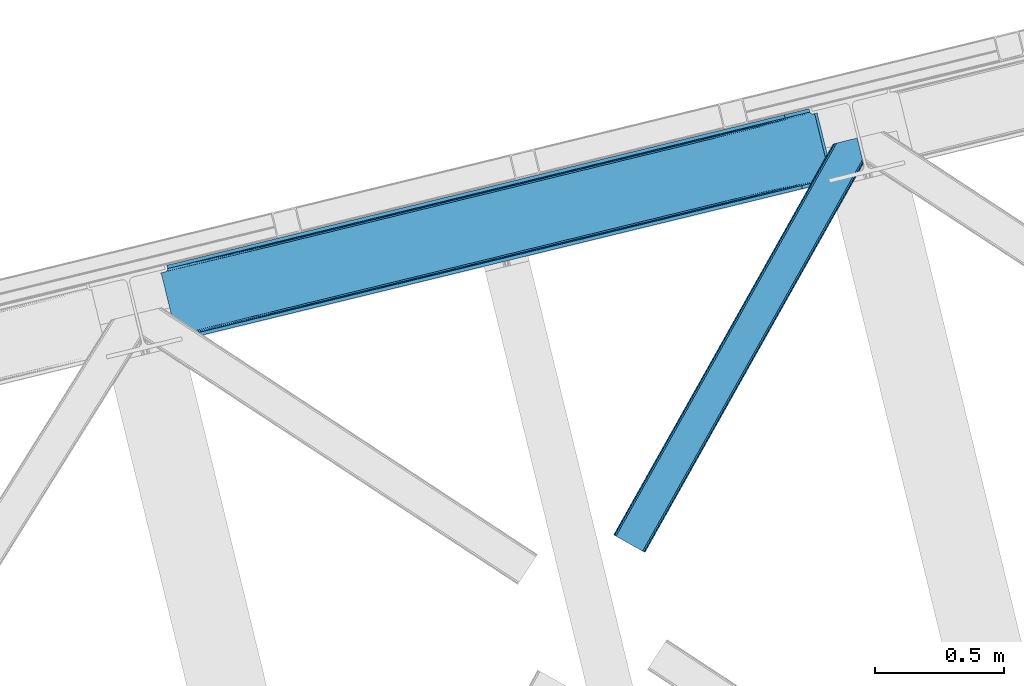
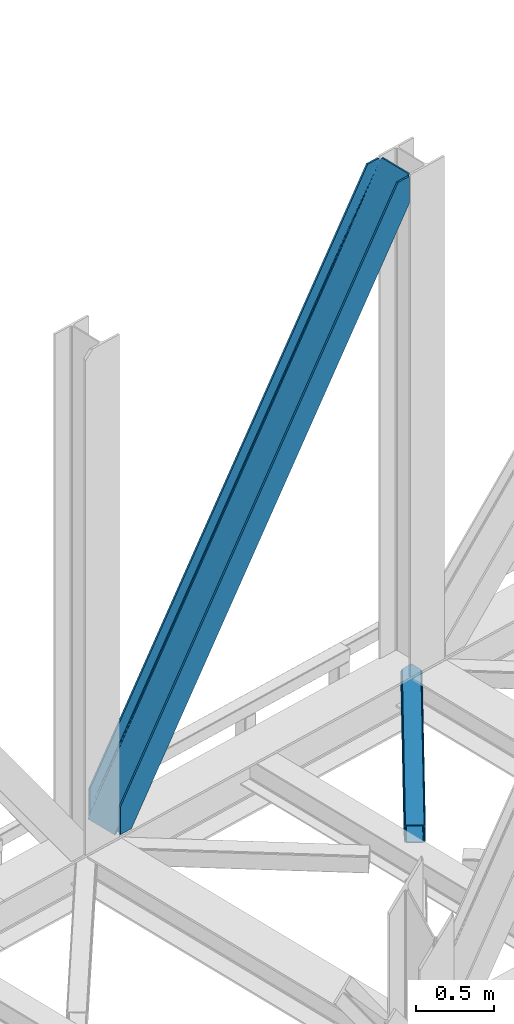
# One storey, part 78 of 92: 2 members.
"""IFC4 building model written with IfcOpenShell, lengths in millimetres."""

from ifc_helpers import new_model, entity, si_unit, converted_unit, derived_unit, direction, frame, origin, place, context, subcontext, project, spatial, triangles, type_object, element, save


model = new_model("IFC4")

# Units and contexts
model_context = context("Model", 3, precision=0.01, world=origin(), true_north=direction((6.12303176911189e-17, 1.0)))
plan_context = context("Plan", 3, precision=0.01, world=origin(), true_north=direction((6.12303176911189e-17, 1.0)))
body_context = subcontext(model_context, "Body", "Model", "MODEL_VIEW")
ifc_project = project(units=[si_unit("LENGTHUNIT", "METRE", prefix="MILLI"), si_unit("AREAUNIT", "SQUARE_METRE"), si_unit("VOLUMEUNIT", "CUBIC_METRE"), converted_unit("PLANEANGLEUNIT", "DEGREE", entity("IfcRatioMeasure", 0.0174532925199433), si_unit("PLANEANGLEUNIT", "RADIAN"), dimensions=[0, 0, 0, 0, 0, 0, 0]), si_unit("MASSUNIT", "GRAM", prefix="KILO"), derived_unit("MASSDENSITYUNIT", [(si_unit("MASSUNIT", "GRAM", prefix="KILO"), 1), (si_unit("LENGTHUNIT", "METRE"), -3)]), derived_unit("MOMENTOFINERTIAUNIT", [(si_unit("LENGTHUNIT", "METRE"), 4)]), si_unit("TIMEUNIT", "SECOND"), si_unit("FREQUENCYUNIT", "HERTZ"), si_unit("THERMODYNAMICTEMPERATUREUNIT", "DEGREE_CELSIUS"), derived_unit("THERMALTRANSMITTANCEUNIT", [(si_unit("MASSUNIT", "GRAM", prefix="KILO"), 1), (si_unit("THERMODYNAMICTEMPERATUREUNIT", "KELVIN"), -1), (si_unit("TIMEUNIT", "SECOND"), -3)]), derived_unit("VOLUMETRICFLOWRATEUNIT", [(si_unit("LENGTHUNIT", "METRE"), 3), (si_unit("TIMEUNIT", "SECOND"), -1)]), derived_unit("MASSFLOWRATEUNIT", [(si_unit("MASSUNIT", "GRAM", prefix="KILO"), 1), (si_unit("TIMEUNIT", "SECOND"), -1)]), derived_unit("ROTATIONALFREQUENCYUNIT", [(si_unit("TIMEUNIT", "SECOND"), -1)]), si_unit("ELECTRICCURRENTUNIT", "AMPERE"), si_unit("ELECTRICVOLTAGEUNIT", "VOLT"), si_unit("POWERUNIT", "WATT"), si_unit("FORCEUNIT", "NEWTON", prefix="KILO"), si_unit("ILLUMINANCEUNIT", "LUX"), si_unit("LUMINOUSFLUXUNIT", "LUMEN"), si_unit("LUMINOUSINTENSITYUNIT", "CANDELA"), derived_unit("USERDEFINED", [(si_unit("MASSUNIT", "GRAM", prefix="KILO"), -1), (si_unit("LENGTHUNIT", "METRE"), -2), (si_unit("TIMEUNIT", "SECOND"), 3), (si_unit("LUMINOUSFLUXUNIT", "LUMEN"), 1)]), derived_unit("LINEARVELOCITYUNIT", [(si_unit("LENGTHUNIT", "METRE"), 1), (si_unit("TIMEUNIT", "SECOND"), -1)]), si_unit("PRESSUREUNIT", "PASCAL"), derived_unit("USERDEFINED", [(si_unit("LENGTHUNIT", "METRE"), -2), (si_unit("MASSUNIT", "GRAM", prefix="KILO"), 1), (si_unit("TIMEUNIT", "SECOND"), -2)]), derived_unit("LINEARFORCEUNIT", [(si_unit("MASSUNIT", "GRAM", prefix="KILO"), 1), (si_unit("LENGTHUNIT", "METRE"), 1), (si_unit("TIMEUNIT", "SECOND"), -2), (si_unit("LENGTHUNIT", "METRE"), -1)]), derived_unit("PLANARFORCEUNIT", [(si_unit("MASSUNIT", "GRAM", prefix="KILO"), 1), (si_unit("LENGTHUNIT", "METRE"), 1), (si_unit("TIMEUNIT", "SECOND"), -2), (si_unit("LENGTHUNIT", "METRE"), -2)])], contexts=[model_context, plan_context])

# Site, building, storey
site_placement = place(None, origin())
site = spatial("IfcSite", under=ifc_project, at=site_placement, CompositionType="ELEMENT")
building_placement = place(site_placement, origin())
building = spatial("IfcBuilding", under=site, at=building_placement, CompositionType="ELEMENT")
storey_placement = place(building_placement, frame((0.0, 0.0, 15900.0)))
storey = spatial("IfcBuildingStorey", under=building, at=storey_placement, Name="05", CompositionType="ELEMENT", Elevation=15900.0)

# Members
member_type_1 = type_object("IfcMemberType", PredefinedType="BRACE")
member_1_placement = place(storey_placement, frame((-11645.76, 17824.6, 3695.0)))
element("IfcMember", 1, at=member_1_placement, inside=storey, type_object=member_type_1, ObjectType="Steel Vertical Brace", PredefinedType="BRACE", context=body_context, shape_type="Tessellation", body=[
    triangles([(2543.71740875244, 876.026760864261, 3910.2403930664), (2543.86100463867, 877.205758666994, 3909.96134033203), (2542.34249267578, 876.834851074222, 3911.00081176758), (2544.23714447021, 869.063232421875, 3911.00081176758), (2527.1870223999, 873.140890502931, 3906.29412231445), (2530.23276672363, 873.882705688477, 3911.00081176758), (2527.1870223999, 873.140890502931, 3884.1908203125), (2518.86892547608, 874.429183959961, 3898.31321411133), (2521.01472473145, 873.423431396484, 3899.16199951172), (2522.8994934082, 872.957180786136, 3877.06799926758), (2518.86892547608, 874.429183959961, 3868.81036376953), (2517.28820800781, 875.594229125978, 3898.850390625), (2517.28820800781, 875.594229125978, 3864.49202270508), (2515.87201538086, 877.455743408205, 3857.29478759765), (2515.70574645996, 877.331332397462, 3901.61533813476), (2513.89597320557, 881.222955322268, 3911.00081176758), (2514.70987701416, 878.98239440918, 3851.39514770508), (2514.17793273926, 880.262548828126, 3838.64708862305), (2514.70987701416, 878.98239440918, 3906.82664794922), (2514.37326965332, 879.734674072268, 3911.00081176758), (2514.17793273926, 880.262548828126, 3698.36960449219), (2513.89597320557, 881.222955322268, 3698.30216674805), (2522.8994934082, 872.957180786136, 3900.77120361328), (1281.82757263184, 579.864605712894, 1933.79126586914), (121.508862304689, 297.023730468751, 0.0), (1706.06330566406, 683.275735473635, 2589.5349609375), (2130.29787597656, 786.688027954104, 3245.28098144531), (857.58835144043, 476.451150512698, 1278.04757080078), (30.7527740478527, 274.901824951172, 0.0), (433.353781127931, 373.040020751956, 622.301550292967), (2511.05370483398, 892.881546020508, 3698.30216674805), (118.429980468751, 309.654354858401, 0.0), (2511.05370483398, 892.881546020508, 3911.00081176758), (2415.21013641357, 869.519018554689, 3911.00081176758), (23.883425903321, 286.608087158205, 214.700848388671), (23.883425903321, 286.608087158205, 0.0), (26.9576568603516, 273.658877563477, 0.0), (26.7251129150391, 274.948333740234, 0.0), (26.7251129150391, 274.948333740234, 214.700848388671), (2509.04452514648, 879.011462402344, 3911.00081176758), (2418.28901824951, 856.888394165042, 3911.00081176758), (26.9169616699219, 273.965835571289, 214.633410644528), (1250.04927978516, 572.117404174805, 1964.95680541992), (1676.92671203613, 676.173843383789, 2624.78862304687), (2103.8058883667, 780.230282592776, 3284.61811523437), (823.166033935548, 468.060964965822, 1305.12731323242), (26.9169616699219, 273.965835571289, 74.3536010742173), (396.287438964844, 364.004525756838, 645.295495605467), (25.435656738282, 266.62907409668, 14.6874755859353), (23.9973724365245, 264.751281738281, 13.8410156249993), (22.5346710205085, 263.467639160157, 35.9326904296868), (25.435656738282, 266.62907409668, 44.192651367186), (26.2995574951183, 268.389431762698, 14.1502990722656), (26.0007385253921, 268.181304931641, 48.2249633789033), (26.9088226318363, 270.661386108401, 54.6571289062485), (26.9088226318363, 270.661386108401, 11.3853515624978), (27.0332336425781, 272.584524536134, 61.6055419921868), (27.0332336425781, 272.584524536134, 6.17404174804688), (22.5346710205085, 263.467639160157, 12.2294860839829), (18.6395599365242, 261.656121826174, 28.8121948242188), (18.6395599365242, 261.656121826174, 6.70889282226563), (0.0, 257.112213134766, 0.0), (14.3014526367188, 260.598046875002, 0.0), (412.366690063478, 356.486380004884, 636.079779052732), (0.597637939454216, 256.057626342776, 0.0), (4.08579711914172, 249.874282836914, 0.0), (2122.62276306152, 766.289273071292, 3274.64197998047), (2534.31914520264, 866.644775390625, 3911.00081176758), (2530.82982330322, 872.828118896487, 3911.00081176758), (2119.88455810547, 772.712136840823, 3275.40239868164), (2109.70145874024, 780.257025146486, 3280.80206909179), (2115.34762573242, 777.616488647462, 3277.56505737305), (407.82975769043, 361.391894531251, 638.242437744138), (402.183590698243, 364.031268310548, 641.479449462888), (415.109545898438, 350.064678955081, 635.319360351561), (829.062185668947, 468.087707519531, 1301.30894165039), (1255.93961791992, 572.142984008791, 1961.14075927734), (1682.81821289063, 676.199423217775, 2620.97025146484), (834.707189941408, 465.447171020511, 1298.07192993164), (1261.58578491211, 569.503610229494, 1957.90374755859), (1688.46903076172, 673.561212158205, 2617.73323974609), (839.24877319336, 460.543981933595, 1295.90927124023), (1266.12736816406, 564.600421142579, 1955.74108886719), (1693.00596313477, 668.656860351563, 2615.57058105469), (841.988140869142, 454.121118164065, 1295.15117797851), (1268.86557312012, 558.177557373048, 1954.98067016601), (1695.74416809082, 662.233996582032, 2614.81248779297), (428.11107788086, 370.350650024415, 626.119921874997), (424.31247253418, 365.409091186524, 629.35693359375), (2119.48225708008, 772.614468383792, 3254.49669799805), (2121.25307922363, 779.057098388672, 3252.33403930664), (423.061386108398, 352.004095458986, 632.280010986327), (14.0096099853527, 252.292739868164, 0.0), (14.2619201660164, 259.388818359377, 0.0), (422.53699951172, 358.966461181641, 631.519592285156), (2125.05110321045, 783.998657226563, 3249.09702758789), (846.772732543946, 462.377590942386, 1287.26328735351), (847.297119140625, 455.415225219727, 1288.02370605469), (1271.00730285645, 565.789883422854, 1943.00930786133), (1271.53168945313, 558.827517700196, 1943.76740112304), (1695.24303588867, 669.201013183596, 2598.75300292969), (1695.76742248535, 662.238647460938, 2599.5110961914), (2120.00199279785, 765.650939941406, 3255.25711669922), (848.548205566407, 468.821383666993, 1285.10062866211), (1272.78277587891, 572.232513427734, 1940.84664916992), (1697.01850891113, 675.644805908203, 2596.59034423828), (852.345648193361, 473.762942504884, 1281.86361694336), (1276.58138122559, 577.175234985352, 1937.60963745117), (1700.81595153809, 680.586364746094, 2593.35333251953), (2589.49949798584, 640.273709106448, 3911.00081176758), (2177.80311584473, 539.918206787112, 3274.64197998047), (1324.04592590332, 331.805328369141, 1954.98067016601), (1750.92452087402, 435.861767578128, 2614.81248779297), (897.168493652345, 227.750051879884, 1295.15117797851), (470.289898681642, 123.693612670901, 635.319360351561), (59.2673126220707, 23.50205383301, 0.0), (2599.41749725342, 642.691003417971, 3911.00081176758), (2175.18234558106, 539.278710937502, 3255.25711669922), (1750.94777526856, 435.867581176761, 2599.5110961914), (1326.71204223633, 332.455288696292, 1943.76740112304), (902.477471923828, 229.044158935547, 1288.02370605469), (478.241738891602, 125.631866455078, 632.280010986327), (69.1899627685561, 25.9216735839873, 0.0), (59.015002441407, 16.4071380615242, 0.0), (72.6781219482436, 19.7383300781257, 0.0), (58.9696563720718, 15.1955841064482, 0.0), (73.2711090087905, 18.6825805664084, 0.0), (77.6092163085941, 19.739492797853, 6.70889282226563), (77.6092163085941, 19.739492797853, 28.8121948242188), (2589.24718780518, 633.177630615235, 3911.00081176758), (2601.31214904785, 634.918222045901, 3911.00081176758), (2589.2024230957, 631.967239379883, 3911.00081176758), (2602.83066101074, 635.289129638673, 3909.96134033203), (2602.16035308838, 636.269302368164, 3910.2403930664), (2586.15667877197, 631.22426147461, 3906.29412231445), (2586.15667877197, 631.22426147461, 3884.1908203125), (2572.75110168457, 617.663461303713, 3911.00081176758), (2577.81474609375, 619.473815917969, 3911.00081176758), (2577.76765594482, 620.297021484377, 3906.82664794922), (2172.75865631104, 521.571652221683, 3280.80206909179), (2577.89206695557, 622.220159912111, 3901.61533813476), (2578.49726257324, 624.490951538086, 3898.850390625), (2582.2662185669, 629.413906860354, 3900.77120361328), (2178.32750244141, 532.955841064453, 3275.40239868164), (2580.80293579102, 628.130264282227, 3899.15967407226), (2579.36465148926, 626.252471923828, 3898.31321411133), (2176.55668029785, 526.513211059573, 3277.56505737305), (470.809634399415, 116.730084228519, 636.079779052732), (469.03881225586, 110.288616943362, 638.242437744138), (81.900814819337, 19.9232025146484, 35.9326904296868), (85.9319641113289, 18.4523620605469, 44.192651367186), (87.5086120605483, 17.2861541748061, 48.5109924316384), (2167.51188354492, 518.882281494141, 3284.61811523437), (459.994015502931, 102.656524658203, 645.295495605467), (465.24020690918, 105.345895385744, 641.479449462888), (90.6235382080085, 12.618997192385, 74.3536010742173), (90.0910125732426, 13.899151611331, 61.6055419921868), (88.9282928466801, 15.4258026123061, 55.7059020996094), (897.692880249024, 220.787686157229, 1295.90927124023), (1324.5703125, 324.844125366213, 1955.74108886719), (1751.4489074707, 428.899401855469, 2615.57058105469), (895.916244506836, 214.343893432619, 1298.07192993164), (1322.79483947754, 318.400332641602, 1957.90374755859), (1749.67808532715, 422.457934570313, 2617.73323974609), (892.118801879884, 209.402334594728, 1301.30894165039), (1318.99739685059, 313.458773803712, 1961.14075927734), (1745.87599182129, 417.514050292972, 2620.97025146484), (886.872610473634, 206.71296386719, 1305.12731323242), (1313.75469360352, 310.770565795901, 1964.95680541992), (1740.63328857422, 414.827005004885, 2624.78862304687), (90.6235382080085, 12.618997192385, 214.633410644528), (2481.9955947876, 595.541555786134, 3911.00081176758), (491.167694091797, 111.666439819339, 626.119921874997), (89.0945617675789, 15.5502136230498, 11.3853515624978), (87.5086120605483, 17.2861541748061, 14.1502990722656), (90.0910125732426, 13.899151611331, 6.17404174804688), (480.981106567384, 119.210165405275, 631.519592285156), (83.7855834960938, 19.4581146240234, 13.8386901855447), (81.900814819337, 19.9232025146484, 12.2294860839829), (85.9319641113289, 18.4523620605469, 14.6874755859353), (485.52152709961, 114.305813598636, 629.35693359375), (2182.46213378906, 527.953820800783, 3252.33403930664), (2582.2662185669, 629.413906860354, 3877.06799926758), (2579.36465148926, 626.252471923828, 3868.81036376953), (2177.92520141602, 532.858172607423, 3254.49669799805), (2578.79608154297, 624.697915649416, 3864.77572631836), (2577.89206695557, 622.220159912111, 3858.34588623047), (2188.10830078125, 525.313284301759, 3249.09702758789), (2577.76765594482, 620.297021484377, 3851.39514770508), (94.4593505859375, 13.5538238525405, 0.0), (90.5188934326179, 12.9108398437529, 0.0), (497.059194946291, 111.692019653321, 622.301550292967), (2577.88392791748, 618.914547729495, 3838.64708862305), (2194.00445251465, 525.340026855469, 3245.28098144531), (915.403427124023, 215.07756958008, 1281.86361694336), (921.294927978517, 215.10431213379, 1278.04757080078), (1339.63799743652, 318.489862060549, 1937.60963745117), (1345.53414916992, 318.516604614259, 1933.79126586914), (1763.87373046875, 421.900991821291, 2593.35333251953), (1769.76871948242, 421.928897094727, 2589.5349609375), (909.757260131837, 217.718106079104, 1285.10062866211), (1333.99183044434, 321.129235839846, 1940.84664916992), (1758.22756347656, 424.541528320315, 2596.59034423828), (905.215676879883, 222.621295166016, 1287.26328735351), (1329.45024719238, 326.033587646485, 1943.00930786133), (1753.68598022461, 429.444717407227, 2598.75300292969), (90.9049163818363, 11.6585906982436, 0.0), (90.9049163818363, 11.6585906982436, 214.700848388671), (2485.07389526367, 582.910931396487, 3911.00081176758), (93.7466033935561, 0.0, 214.700848388671), (93.7466033935561, 0.0, 0.0), (188.293157958986, 23.046267700196, 0.0), (185.214276123048, 35.6768920898467, 0.0), (2577.88392791748, 618.914547729495, 3698.36960449219), (2578.07577667236, 617.93204956055, 3911.00081176758), (2578.07577667236, 617.93204956055, 3698.30216674805), (2580.91746368408, 606.273458862306, 3698.30216674805), (2580.91746368408, 606.273458862306, 3911.00081176758)], [[1, 2, 3], [3, 4, 1], [3, 5, 6], [5, 3, 2], [7, 5, 2], [8, 9, 10], [10, 11, 8], [8, 11, 12], [13, 12, 11], [14, 15, 12], [16, 17, 18], [19, 15, 14], [16, 20, 19], [19, 17, 16], [14, 17, 19], [18, 21, 22], [22, 16, 18], [13, 14, 12], [9, 23, 10], [5, 7, 23], [10, 23, 7], [21, 24, 25], [26, 21, 27], [21, 26, 24], [21, 18, 27], [28, 25, 24], [29, 25, 30], [28, 30, 25], [31, 22, 32], [22, 21, 25], [25, 32, 22], [16, 22, 33], [31, 33, 22], [34, 31, 35], [31, 34, 33], [32, 35, 31], [36, 35, 32], [32, 29, 36], [29, 32, 25], [37, 38, 29], [38, 36, 29], [38, 39, 35], [35, 36, 38], [16, 33, 40], [20, 16, 40], [34, 40, 33], [34, 41, 40], [39, 34, 35], [41, 39, 42], [39, 41, 34], [41, 42, 43], [43, 44, 41], [44, 45, 41], [40, 41, 45], [46, 43, 42], [42, 47, 48], [48, 46, 42], [49, 50, 51], [51, 52, 49], [53, 49, 52], [52, 54, 53], [55, 56, 53], [57, 58, 55], [56, 55, 58], [38, 37, 58], [58, 47, 38], [39, 38, 47], [47, 42, 39], [57, 47, 58], [54, 55, 53], [50, 59, 51], [51, 59, 60], [61, 60, 59], [60, 61, 62], [63, 62, 61], [64, 65, 66], [67, 68, 69], [70, 8, 12], [70, 69, 23], [23, 9, 70], [9, 8, 70], [69, 5, 23], [69, 6, 5], [71, 72, 12], [12, 15, 71], [19, 40, 45], [45, 71, 19], [73, 74, 57], [57, 55, 73], [64, 51, 60], [60, 65, 64], [60, 62, 65], [64, 73, 54], [54, 52, 64], [52, 51, 64], [55, 54, 73], [74, 48, 47], [47, 57, 74], [19, 20, 40], [15, 19, 71], [12, 72, 70], [69, 70, 67], [66, 75, 64], [76, 46, 48], [48, 74, 76], [77, 43, 46], [46, 76, 77], [78, 44, 43], [43, 77, 78], [71, 45, 78], [44, 78, 45], [79, 76, 73], [74, 73, 76], [80, 77, 79], [76, 79, 77], [81, 78, 80], [77, 80, 78], [72, 71, 78], [78, 81, 72], [82, 79, 64], [73, 64, 79], [83, 80, 79], [79, 82, 83], [84, 81, 80], [80, 83, 84], [70, 72, 81], [81, 84, 70], [85, 82, 64], [64, 75, 85], [86, 83, 82], [82, 85, 86], [87, 84, 86], [83, 86, 84], [67, 70, 87], [84, 87, 70], [88, 89, 53], [53, 56, 88], [30, 88, 58], [58, 29, 30], [90, 10, 7], [7, 1, 90], [7, 2, 1], [90, 91, 13], [13, 11, 90], [11, 10, 90], [92, 93, 94], [95, 49, 53], [95, 94, 61], [61, 59, 95], [59, 50, 95], [50, 49, 95], [94, 63, 61], [53, 89, 95], [94, 95, 92], [14, 91, 17], [14, 13, 91], [91, 96, 17], [18, 17, 96], [96, 27, 18], [58, 37, 29], [56, 58, 88], [97, 98, 92], [92, 95, 97], [99, 100, 98], [98, 97, 99], [101, 102, 100], [100, 99, 101], [90, 103, 102], [102, 101, 90], [1, 4, 90], [103, 90, 4], [104, 97, 95], [95, 89, 104], [105, 99, 104], [97, 104, 99], [106, 101, 105], [99, 105, 101], [91, 90, 101], [101, 106, 91], [107, 104, 88], [89, 88, 104], [108, 105, 107], [104, 107, 105], [109, 106, 105], [105, 108, 109], [96, 91, 106], [106, 109, 96], [28, 107, 88], [88, 30, 28], [24, 108, 107], [107, 28, 24], [26, 109, 24], [108, 24, 109], [27, 96, 26], [109, 26, 96], [110, 68, 67], [87, 111, 67], [112, 113, 87], [112, 87, 86], [67, 111, 110], [87, 113, 111], [85, 114, 112], [112, 86, 85], [85, 75, 115], [66, 116, 75], [85, 115, 114], [75, 116, 115], [4, 117, 118], [119, 103, 118], [100, 102, 119], [100, 119, 120], [118, 103, 4], [119, 102, 103], [98, 100, 120], [120, 121, 98], [121, 122, 92], [123, 93, 122], [121, 92, 98], [122, 93, 92], [66, 116, 93], [116, 124, 125], [124, 126, 125], [62, 65, 63], [65, 66, 94], [93, 116, 123], [127, 125, 126], [125, 123, 116], [93, 94, 66], [94, 63, 65], [128, 129, 126], [126, 127, 128], [110, 130, 131], [130, 132, 131], [6, 69, 3], [3, 69, 68], [110, 117, 68], [68, 117, 4], [110, 131, 117], [4, 3, 68], [133, 134, 131], [117, 131, 134], [131, 135, 133], [131, 132, 135], [135, 136, 133], [137, 138, 139], [140, 141, 142], [140, 139, 141], [130, 143, 135], [144, 145, 143], [144, 146, 145], [143, 130, 144], [135, 132, 130], [144, 147, 142], [142, 146, 144], [111, 144, 130], [148, 115, 116], [149, 150, 151], [148, 124, 129], [129, 149, 148], [129, 150, 149], [124, 126, 129], [151, 152, 149], [116, 124, 148], [130, 110, 111], [142, 147, 140], [137, 139, 153], [140, 153, 139], [154, 155, 156], [157, 156, 155], [157, 149, 158], [157, 155, 149], [152, 158, 149], [159, 114, 148], [115, 148, 114], [160, 112, 159], [114, 159, 112], [161, 113, 112], [112, 160, 161], [144, 111, 113], [113, 161, 144], [162, 159, 148], [148, 149, 162], [163, 160, 162], [159, 162, 160], [164, 161, 163], [160, 163, 161], [147, 144, 164], [161, 164, 144], [165, 162, 149], [149, 155, 165], [166, 163, 162], [162, 165, 166], [167, 164, 163], [163, 166, 167], [140, 147, 167], [164, 167, 147], [168, 165, 154], [155, 154, 165], [169, 166, 168], [165, 168, 166], [170, 167, 169], [166, 169, 167], [153, 140, 167], [167, 170, 153], [169, 171, 172], [172, 153, 170], [153, 172, 137], [170, 169, 172], [171, 169, 168], [168, 154, 171], [156, 171, 154], [173, 174, 175], [173, 176, 174], [177, 178, 179], [177, 180, 178], [179, 128, 177], [128, 125, 177], [128, 127, 125], [177, 181, 175], [175, 180, 177], [122, 177, 125], [182, 183, 184], [185, 134, 136], [136, 182, 185], [136, 183, 182], [134, 133, 136], [184, 186, 182], [182, 186, 187], [187, 188, 182], [187, 189, 188], [190, 191, 176], [173, 192, 176], [190, 176, 192], [189, 193, 188], [194, 188, 193], [125, 123, 122], [175, 181, 173], [195, 196, 173], [192, 173, 196], [197, 198, 195], [196, 195, 198], [199, 200, 198], [198, 197, 199], [188, 194, 200], [200, 199, 188], [201, 195, 173], [173, 181, 201], [202, 197, 195], [195, 201, 202], [203, 199, 197], [197, 202, 203], [182, 188, 199], [199, 203, 182], [204, 201, 177], [181, 177, 201], [205, 202, 201], [201, 204, 205], [206, 203, 205], [202, 205, 203], [185, 182, 206], [203, 206, 182], [121, 204, 122], [177, 122, 204], [120, 205, 121], [204, 121, 205], [119, 206, 205], [205, 120, 119], [118, 185, 206], [206, 119, 118], [117, 134, 185], [185, 118, 117], [180, 151, 150], [150, 179, 178], [175, 158, 152], [175, 152, 151], [151, 180, 175], [207, 157, 176], [176, 157, 158], [158, 174, 176], [207, 208, 156], [171, 156, 208], [156, 157, 207], [176, 191, 207], [175, 174, 158], [150, 178, 180], [179, 150, 129], [129, 128, 179], [208, 172, 171], [209, 208, 210], [208, 209, 172], [211, 210, 207], [208, 207, 210], [212, 190, 211], [190, 212, 213], [191, 207, 190], [207, 211, 190], [198, 214, 213], [194, 214, 200], [194, 193, 214], [198, 200, 214], [213, 196, 198], [192, 196, 213], [213, 190, 192], [146, 184, 183], [183, 143, 145], [142, 186, 184], [142, 187, 186], [184, 146, 142], [215, 189, 139], [187, 141, 139], [139, 189, 187], [214, 193, 216], [215, 216, 193], [193, 189, 215], [139, 138, 215], [142, 141, 187], [183, 145, 146], [136, 135, 143], [143, 183, 136], [217, 209, 210], [217, 218, 209], [210, 212, 217], [211, 212, 210], [215, 138, 137], [218, 215, 137], [137, 209, 218], [209, 137, 172], [214, 216, 213], [216, 217, 212], [212, 213, 216], [218, 217, 216], [216, 215, 218]]),
])
member_type_2 = type_object("IfcMemberType", PredefinedType="BRACE")
member_2_placement = place(storey_placement, frame((-9892.02, 16998.99, 3510.0)))
element("IfcMember", 2, at=member_2_placement, inside=storey, type_object=member_type_2, ObjectType="Steel Horizontal Brace", PredefinedType="BRACE", context=body_context, shape_type="Tessellation", body=[
    triangles([(963.930697631835, 1521.10947875976, 138.667117309571), (961.605839538573, 1530.64726867676, 139.999594116212), (106.810922241211, 8.56924438476563, 139.999594116212), (112.650100708008, 5.29037475585938, 138.667117309571), (965.901507568358, 1513.02508850098, 134.874325561526), (117.598635864257, 2.50914916992042, 134.874325561526), (967.21828765869, 1507.62192993164, 129.197927856447), (120.908898925782, 0.65228576660229, 129.197927856447), (967.680468749999, 1505.72553405762, 122.500662231447), (122.068130493164, 0.0, 122.500662231447), (967.680468749999, 1505.72553405762, 17.5000946044929), (122.068130493164, 0.0, 17.5000946044929), (15.2572082519528, 59.9835479736321, 139.999594116212), (873.405409240722, 1588.02516174316, 139.999594116212), (943.45694732666, 1605.10086364746, 139.999594116212), (851.919511413575, 1582.78827209473, 129.197927856447), (850.152758789061, 1582.35690307617, 122.500662231447), (1.16388244628797, 67.9005065917954, 129.197927856447), (0.0, 68.5527923583977, 122.500662231447), (856.962226867676, 1584.0172668457, 134.874325561526), (4.46949462890552, 66.04248046875, 134.874325561526), (864.503627014159, 1585.8555267334, 138.667117309571), (9.4215179443363, 63.2635803222656, 138.667117309571), (850.152758789061, 1582.35690307617, 17.5000946044929), (0.0, 68.5527923583977, 17.5000946044929), (1.16388244628797, 67.9005065917954, 10.8028289794929), (809.934864807128, 1506.81616516113, 9.52034912109593), (809.674415588379, 1505.78367004394, 9.02037963867406), (4.46949462890552, 66.04248046875, 5.12526855468968), (809.409315490722, 1504.7488494873, 8.52041015625218), (810.327864074707, 1500.98047485352, 5.12526855468968), (852.276466369629, 1582.87431335449, 10.8679412841811), (852.710160827637, 1582.98012084961, 9.52034912109593), (812.29867401123, 1492.89608459473, 1.33247680664135), (814.623532104491, 1483.35829467774, 0.0), (9.4215179443363, 63.2635803222656, 1.33247680664135), (15.2572082519528, 59.9835479736321, 0.0), (842.022441101073, 1370.95817871094, 0.0), (106.810922241211, 8.56924438476563, 0.0), (876.670907592774, 1379.40417480469, 0.0), (814.517724609375, 1484.6570526123, 8.82736816406396), (814.736315917968, 1482.89553222656, 8.42274169922166), (814.460751342773, 1485.77442626953, 9.13665161133031), (814.401452636719, 1486.88249816895, 9.44360961914208), (814.630508422852, 1487.55222473144, 9.52034912109593), (870.68522644043, 1587.36241149902, 9.52034912109593), (817.053616333007, 1473.39029846191, 6.99957275390625), (842.022441101073, 1370.95817871094, 6.99957275390625), (15.5234710693348, 59.8347198486335, 8.3320495605476), (21.3638122558586, 56.5558502197273, 6.99957275390625), (866.261659240723, 1586.28340759277, 12.1260040283232), (10.5714477539059, 62.6147827148452, 12.1260040283232), (861.223013305664, 1585.05557556152, 17.8035644531265), (859.452191162109, 1584.62420654297, 24.4996673583992), (7.26467285156286, 64.4728088378906, 17.8035644531265), (6.1054412841786, 65.1250946044929, 24.4996673583992), (100.704318237304, 11.9957794189468, 6.99957275390625), (867.366824340819, 1377.13687133789, 6.99957275390625), (885.567457580566, 1381.57380981445, 1.33247680664135), (879.391090393066, 1380.06808776856, 9.52034912109593), (893.113508605957, 1383.41323242187, 5.12526855468968), (876.06978149414, 1379.25767211914, 8.82504272460938), (897.365574645995, 1384.44921569824, 9.52034912109593), (963.083074951172, 1500.72467651367, 10.8702667236357), (120.908898925782, 0.65228576660229, 10.8028289794929), (117.598635864257, 2.50914916992042, 5.12526855468968), (967.671166992188, 1505.76390380859, 16.5199218750022), (961.988374328614, 1499.52126159668, 9.52034912109593), (112.650100708008, 5.29037475585938, 1.33247680664135), (960.31696472168, 1517.3771484375, 12.1260040283232), (964.582402038573, 1518.43522338867, 16.5199218750022), (957.29273071289, 1518.78520202637, 9.52034912109593), (114.803457641601, 4.07998352050708, 17.8035644531265), (115.967340087891, 3.42769775390479, 24.4996673583992), (965.250965881347, 1515.69353027344, 24.4996673583992), (964.69518585205, 1517.9724609375, 17.8686767578147), (111.496682739258, 5.93800964355614, 12.1260040283232), (106.544659423827, 8.71690979004052, 8.3320495605476), (965.250965881347, 1515.69353027344, 115.501089477541), (115.967340087891, 3.42769775390479, 115.501089477541), (964.788203430175, 1517.59108886719, 122.196029663086), (963.471423339843, 1522.9930847168, 127.87475280762), (961.500613403319, 1531.07863769531, 131.667544555665), (959.175755310058, 1540.61526489258, 133.000021362306), (943.45694732666, 1605.10086364746, 133.000021362306), (114.803457641601, 4.07998352050708, 122.196029663086), (111.496682739258, 5.93800964355614, 127.87475280762), (106.544659423827, 8.71690979004052, 131.667544555665), (100.704318237304, 11.9957794189468, 133.000021362306), (10.5714477539059, 62.6147827148452, 127.87475280762), (21.3638122558586, 56.5558502197273, 133.000021362306), (15.5234710693348, 59.8347198486335, 131.667544555665), (6.1054412841786, 65.1250946044929, 115.501089477541), (7.26467285156286, 64.4728088378906, 122.196029663086), (861.223013305664, 1585.05557556152, 122.196029663086), (873.807710266114, 1588.12283020019, 131.667544555665), (882.70484161377, 1590.29246520996, 133.000021362306), (866.261659240723, 1586.28340759277, 127.87475280762), (859.452191162109, 1584.62420654297, 115.501089477541)], [[1, 2, 3], [3, 4, 1], [5, 1, 4], [4, 6, 5], [7, 5, 6], [6, 8, 7], [9, 7, 8], [8, 10, 9], [11, 9, 10], [10, 12, 11], [13, 2, 14], [13, 3, 2], [2, 15, 14], [16, 17, 18], [19, 18, 17], [20, 16, 21], [18, 21, 16], [22, 20, 23], [21, 23, 20], [14, 22, 13], [23, 13, 22], [17, 24, 25], [25, 19, 17], [26, 25, 24], [27, 28, 29], [30, 29, 28], [30, 31, 29], [26, 32, 27], [27, 29, 26], [32, 33, 27], [34, 35, 36], [37, 36, 35], [31, 34, 29], [36, 29, 34], [24, 32, 26], [38, 37, 35], [39, 38, 40], [38, 39, 37], [41, 42, 30], [43, 41, 30], [44, 43, 28], [45, 27, 46], [33, 46, 27], [34, 42, 35], [30, 42, 31], [31, 42, 34], [47, 35, 42], [47, 38, 35], [38, 47, 48], [49, 50, 47], [44, 51, 52], [44, 46, 51], [52, 49, 42], [43, 52, 41], [43, 44, 52], [52, 42, 41], [47, 42, 49], [53, 54, 55], [56, 55, 54], [51, 53, 52], [55, 52, 53], [48, 57, 58], [50, 48, 47], [48, 50, 57], [59, 60, 61], [58, 38, 48], [58, 62, 40], [58, 40, 38], [40, 60, 59], [61, 60, 63], [62, 60, 40], [64, 65, 63], [65, 66, 61], [61, 63, 65], [12, 65, 64], [64, 11, 12], [64, 67, 11], [63, 68, 64], [59, 61, 66], [66, 69, 59], [40, 59, 69], [69, 39, 40], [70, 67, 64], [70, 71, 67], [64, 72, 70], [68, 72, 64], [63, 60, 68], [72, 68, 60], [73, 74, 75], [73, 71, 70], [73, 76, 71], [77, 70, 60], [60, 78, 77], [60, 62, 78], [70, 72, 60], [78, 62, 58], [58, 57, 78], [70, 77, 73], [75, 76, 73], [79, 75, 74], [74, 80, 79], [76, 67, 71], [9, 11, 75], [11, 76, 75], [75, 79, 9], [11, 67, 76], [81, 9, 79], [7, 9, 81], [5, 81, 82], [81, 5, 7], [82, 1, 5], [83, 1, 82], [83, 84, 2], [83, 2, 1], [84, 15, 2], [84, 85, 15], [81, 79, 86], [80, 86, 79], [82, 81, 87], [86, 87, 81], [83, 82, 88], [87, 88, 82], [84, 83, 89], [88, 89, 83], [8, 87, 86], [80, 12, 10], [8, 86, 10], [8, 6, 87], [86, 80, 10], [87, 6, 4], [89, 3, 13], [3, 88, 4], [88, 3, 89], [88, 87, 4], [65, 77, 66], [74, 12, 80], [12, 73, 65], [73, 12, 74], [65, 73, 77], [39, 57, 37], [69, 66, 77], [77, 78, 69], [78, 57, 39], [39, 69, 78], [90, 23, 21], [13, 91, 89], [13, 92, 91], [92, 13, 23], [90, 92, 23], [93, 19, 25], [18, 94, 90], [21, 18, 90], [94, 18, 19], [93, 94, 19], [36, 52, 29], [37, 57, 50], [50, 49, 37], [49, 52, 36], [36, 37, 49], [26, 29, 52], [25, 56, 93], [55, 25, 26], [25, 55, 56], [55, 26, 52], [95, 17, 16], [96, 22, 14], [15, 97, 14], [97, 15, 85], [97, 96, 14], [98, 22, 96], [98, 95, 20], [20, 22, 98], [16, 20, 95], [54, 24, 17], [51, 33, 53], [95, 99, 17], [51, 46, 33], [54, 53, 24], [99, 54, 17], [32, 24, 53], [53, 33, 32], [91, 84, 89], [84, 91, 97], [85, 84, 97], [54, 99, 56], [93, 56, 99], [96, 97, 91], [91, 92, 96], [98, 96, 92], [92, 90, 98], [95, 98, 90], [90, 94, 95], [99, 95, 94], [94, 93, 99]]),
])

save(model, "model.ifc")
